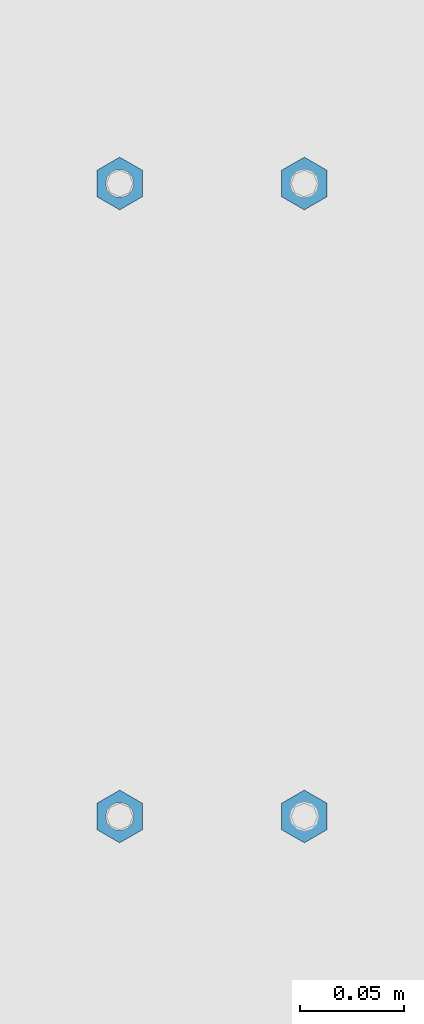
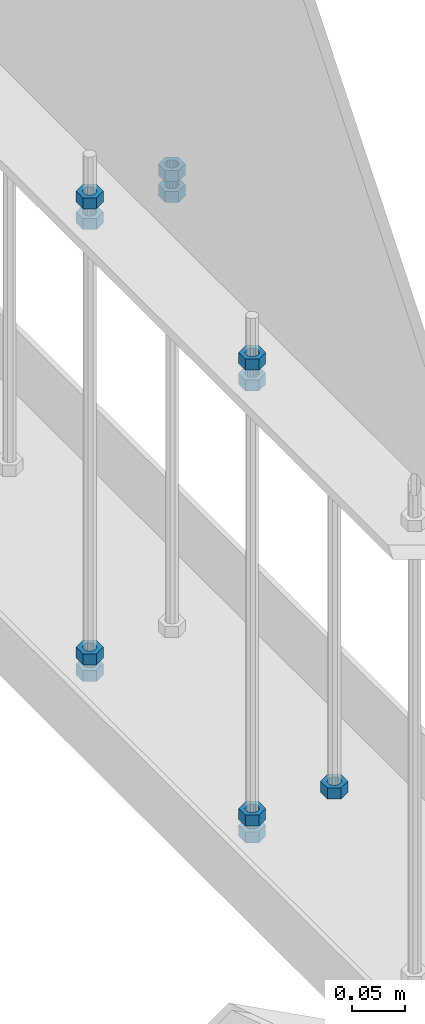
# One storey, part 294 of 975: 11 columns.
"""IFC2X3 building model written with IfcOpenShell, lengths in millimetres."""

from ifc_helpers import new_model, si_unit, frame, origin_with_axes, place, context, subcontext, project, spatial, faceted_brep, material, type_object, element, save


model = new_model("IFC2X3")

# Units and contexts
model_context = context("Model", 3, precision=1e-05, world=origin_with_axes())
body_context = subcontext(model_context, "Body", "Model", "MODEL_VIEW")
ifc_project = project(units=[si_unit("LENGTHUNIT", "METRE", prefix="MILLI"), si_unit("AREAUNIT", "SQUARE_METRE"), si_unit("VOLUMEUNIT", "CUBIC_METRE"), si_unit("MASSUNIT", "GRAM", prefix="KILO"), si_unit("TIMEUNIT", "SECOND"), si_unit("PLANEANGLEUNIT", "RADIAN"), si_unit("SOLIDANGLEUNIT", "STERADIAN"), si_unit("THERMODYNAMICTEMPERATUREUNIT", "DEGREE_CELSIUS"), si_unit("LUMINOUSINTENSITYUNIT", "LUMEN")], contexts=[model_context])

# Site, building, storey
site_placement = place(None, origin_with_axes())
site = spatial("IfcSite", under=ifc_project, at=site_placement, CompositionType="ELEMENT")
building_placement = place(site_placement, origin_with_axes())
building = spatial("IfcBuilding", under=site, at=building_placement, Name="Undefined", CompositionType="ELEMENT")
storey_placement = place(building_placement, origin_with_axes())
storey = spatial("IfcBuildingStorey", under=building, at=storey_placement, Name="Undefined", CompositionType="ELEMENT", Elevation=0.0)

# Columns
ifc_material = material(Name="STEEL/A307")
column_type = type_object("IfcColumnType", Name="1/2_HEAVY_HEX_NUT", PredefinedType="NOTDEFINED")
column_1_placement = place(storey_placement, frame((8274.05, 21726.525, 3400.425), z_axis=(-0.999999999999998, 6.90000001668524e-08, 0.0), x_axis=(0.0, 0.0, 1.0)))
element("IfcColumn", 1, at=column_1_placement, inside=storey, type_object=column_type, material=ifc_material, Name="NUT", ObjectType="1/2_HEAVY_HEX_NUT", context=body_context, shape_type="Brep", body=[
    faceted_brep([(0.0, -12.6999998092506, -1.09139364212751e-11), (0.0, -6.34999990461802, -11.0000000000218), (12.6999999999998, -6.34999990461802, -11.0000000000218), (12.6999999999998, -12.6999998092506, -1.09139364212751e-11), (0.0, 6.34999990463257, -11.0000000000109), (12.6999999999998, 6.34999990463257, -11.0000000000109), (0.0, 12.6999998092506, 1.09139364212751e-11), (12.6999999999998, 12.6999998092506, 1.09139364212751e-11), (0.0, 6.34999990461802, 11.0000000000218), (12.6999999999998, 6.34999990461802, 11.0000000000218), (0.0, -6.34999990463984, 11.0000000000109), (12.6999999999998, -6.34999990463984, 11.0000000000109), (0.0, -7.27595761418343e-12, 6.75000000000728), (0.0, 2.92871523903523, 6.08153985835088), (12.6999999999998, 2.92871523903523, 6.08153985835088), (12.6999999999998, -7.27595761418343e-12, 6.75000000000728), (0.0, 5.27736250664748, 4.20855616255722), (12.6999999999998, 5.27736250664748, 4.20855616255722), (0.0, 6.58076340721527, 1.50201630420997), (12.6999999999998, 6.58076340721527, 1.50201630420997), (0.0, 6.58076340722255, -1.5020163042027), (12.6999999999998, 6.58076340722255, -1.5020163042027), (0.0, 5.27736250665839, -4.20855616254994), (12.6999999999998, 5.27736250665839, -4.20855616254994), (0.0, 2.92871523904614, -6.08153985834724), (12.6999999999998, 2.92871523904614, -6.08153985834724), (0.0, 3.63797880709171e-12, -6.75000000001273), (12.6999999999998, 3.63797880709171e-12, -6.75000000001273), (0.0, -2.92871523903523, -6.08153985835452), (12.6999999999998, -2.92871523903523, -6.08153985835452), (0.0, -5.27736250665475, -4.20855616255722), (12.6999999999998, -5.27736250665475, -4.20855616255722), (0.0, -6.58076340721891, -1.50201630421179), (12.6999999999998, -6.58076340721891, -1.50201630421179), (0.0, -6.58076340722255, 1.50201630419906), (12.6999999999998, -6.58076340722255, 1.50201630419906), (0.0, -5.27736250665839, 4.20855616254994), (12.6999999999998, -5.27736250665839, 4.20855616254994), (0.0, -2.92871523904614, 6.08153985834724), (12.6999999999998, -2.92871523904614, 6.08153985834724)], [[[0, 1, 2, 3]], [[1, 4, 5, 2]], [[4, 6, 7, 5]], [[6, 8, 9, 7]], [[8, 10, 11, 9]], [[10, 0, 3, 11]], [[12, 13, 14, 15]], [[13, 16, 17, 14]], [[16, 18, 19, 17]], [[18, 20, 21, 19]], [[20, 22, 23, 21]], [[22, 24, 25, 23]], [[24, 26, 27, 25]], [[26, 28, 29, 27]], [[28, 30, 31, 29]], [[30, 32, 33, 31]], [[32, 34, 35, 33]], [[34, 36, 37, 35]], [[36, 38, 39, 37]], [[38, 12, 15, 39]], [[5, 7, 9, 11, 3, 2], [17, 19, 21, 23, 25, 27, 29, 31, 33, 35, 37, 39, 15, 14]], [[10, 8, 6, 4, 1, 0], [38, 36, 34, 32, 30, 28, 26, 24, 22, 20, 18, 16, 13, 12]]]),
])
column_2_placement = place(storey_placement, frame((8274.05, 21726.525, 3424.2375), z_axis=(-0.999999999999998, 6.90000001668524e-08, 0.0), x_axis=(0.0, 0.0, 1.0)))
element("IfcColumn", 2, at=column_2_placement, inside=storey, type_object=column_type, material=ifc_material, Name="NUT", ObjectType="1/2_HEAVY_HEX_NUT", context=body_context, shape_type="Brep", body=[
    faceted_brep([(0.0, -12.6999998092506, -1.09139364212751e-11), (0.0, -6.34999990461802, -11.0000000000218), (12.6999999999998, -6.34999990461802, -11.0000000000218), (12.6999999999998, -12.6999998092506, -1.09139364212751e-11), (0.0, 6.34999990463257, -11.0000000000109), (12.6999999999998, 6.34999990463257, -11.0000000000109), (0.0, 12.6999998092506, 1.09139364212751e-11), (12.6999999999998, 12.6999998092506, 1.09139364212751e-11), (0.0, 6.34999990461802, 11.0000000000218), (12.6999999999998, 6.34999990461802, 11.0000000000218), (0.0, -6.34999990463984, 11.0000000000109), (12.6999999999998, -6.34999990463984, 11.0000000000109), (0.0, -7.27595761418343e-12, 6.75000000000728), (0.0, 2.92871523903523, 6.08153985835088), (12.6999999999998, 2.92871523903523, 6.08153985835088), (12.6999999999998, -7.27595761418343e-12, 6.75000000000728), (0.0, 5.27736250664748, 4.20855616255722), (12.6999999999998, 5.27736250664748, 4.20855616255722), (0.0, 6.58076340721527, 1.50201630420997), (12.6999999999998, 6.58076340721527, 1.50201630420997), (0.0, 6.58076340722255, -1.5020163042027), (12.6999999999998, 6.58076340722255, -1.5020163042027), (0.0, 5.27736250665839, -4.20855616254994), (12.6999999999998, 5.27736250665839, -4.20855616254994), (0.0, 2.92871523904614, -6.08153985834724), (12.6999999999998, 2.92871523904614, -6.08153985834724), (0.0, 3.63797880709171e-12, -6.75000000001273), (12.6999999999998, 3.63797880709171e-12, -6.75000000001273), (0.0, -2.92871523903523, -6.08153985835452), (12.6999999999998, -2.92871523903523, -6.08153985835452), (0.0, -5.27736250665475, -4.20855616255722), (12.6999999999998, -5.27736250665475, -4.20855616255722), (0.0, -6.58076340721891, -1.50201630421179), (12.6999999999998, -6.58076340721891, -1.50201630421179), (0.0, -6.58076340722255, 1.50201630419906), (12.6999999999998, -6.58076340722255, 1.50201630419906), (0.0, -5.27736250665839, 4.20855616254994), (12.6999999999998, -5.27736250665839, 4.20855616254994), (0.0, -2.92871523904614, 6.08153985834724), (12.6999999999998, -2.92871523904614, 6.08153985834724)], [[[0, 1, 2, 3]], [[1, 4, 5, 2]], [[4, 6, 7, 5]], [[6, 8, 9, 7]], [[8, 10, 11, 9]], [[10, 0, 3, 11]], [[12, 13, 14, 15]], [[13, 16, 17, 14]], [[16, 18, 19, 17]], [[18, 20, 21, 19]], [[20, 22, 23, 21]], [[22, 24, 25, 23]], [[24, 26, 27, 25]], [[26, 28, 29, 27]], [[28, 30, 31, 29]], [[30, 32, 33, 31]], [[32, 34, 35, 33]], [[34, 36, 37, 35]], [[36, 38, 39, 37]], [[38, 12, 15, 39]], [[5, 7, 9, 11, 3, 2], [17, 19, 21, 23, 25, 27, 29, 31, 33, 35, 37, 39, 15, 14]], [[10, 8, 6, 4, 1, 0], [38, 36, 34, 32, 30, 28, 26, 24, 22, 20, 18, 16, 13, 12]]]),
])
column_3_placement = place(storey_placement, frame((8185.15, 21726.525, 2901.95), z_axis=(-0.999999999999998, 6.90000001668524e-08, 0.0), x_axis=(0.0, 0.0, 1.0)))
element("IfcColumn", 3, at=column_3_placement, inside=storey, type_object=column_type, material=ifc_material, Name="NUT", ObjectType="1/2_HEAVY_HEX_NUT", context=body_context, shape_type="Brep", body=[
    faceted_brep([(0.0, -12.6999998092506, -1.09139364212751e-11), (0.0, -6.34999990461802, -11.0000000000218), (12.6999999999998, -6.34999990461802, -11.0000000000218), (12.6999999999998, -12.6999998092506, -1.09139364212751e-11), (0.0, 6.34999990463257, -11.0000000000109), (12.6999999999998, 6.34999990463257, -11.0000000000109), (0.0, 12.6999998092506, 1.09139364212751e-11), (12.6999999999998, 12.6999998092506, 1.09139364212751e-11), (0.0, 6.34999990461802, 11.0000000000218), (12.6999999999998, 6.34999990461802, 11.0000000000218), (0.0, -6.34999990463984, 11.0000000000109), (12.6999999999998, -6.34999990463984, 11.0000000000109), (0.0, -7.27595761418343e-12, 6.75000000000728), (0.0, 2.92871523903523, 6.08153985835088), (12.6999999999998, 2.92871523903523, 6.08153985835088), (12.6999999999998, -7.27595761418343e-12, 6.75000000000728), (0.0, 5.27736250664748, 4.20855616255722), (12.6999999999998, 5.27736250664748, 4.20855616255722), (0.0, 6.58076340721527, 1.50201630420997), (12.6999999999998, 6.58076340721527, 1.50201630420997), (0.0, 6.58076340722255, -1.5020163042027), (12.6999999999998, 6.58076340722255, -1.5020163042027), (0.0, 5.27736250665839, -4.20855616254994), (12.6999999999998, 5.27736250665839, -4.20855616254994), (0.0, 2.92871523904614, -6.08153985834724), (12.6999999999998, 2.92871523904614, -6.08153985834724), (0.0, 3.63797880709171e-12, -6.75000000001273), (12.6999999999998, 3.63797880709171e-12, -6.75000000001273), (0.0, -2.92871523903523, -6.08153985835452), (12.6999999999998, -2.92871523903523, -6.08153985835452), (0.0, -5.27736250665475, -4.20855616255722), (12.6999999999998, -5.27736250665475, -4.20855616255722), (0.0, -6.58076340721891, -1.50201630421179), (12.6999999999998, -6.58076340721891, -1.50201630421179), (0.0, -6.58076340722255, 1.50201630419906), (12.6999999999998, -6.58076340722255, 1.50201630419906), (0.0, -5.27736250665839, 4.20855616254994), (12.6999999999998, -5.27736250665839, 4.20855616254994), (0.0, -2.92871523904614, 6.08153985834724), (12.6999999999998, -2.92871523904614, 6.08153985834724)], [[[0, 1, 2, 3]], [[1, 4, 5, 2]], [[4, 6, 7, 5]], [[6, 8, 9, 7]], [[8, 10, 11, 9]], [[10, 0, 3, 11]], [[12, 13, 14, 15]], [[13, 16, 17, 14]], [[16, 18, 19, 17]], [[18, 20, 21, 19]], [[20, 22, 23, 21]], [[22, 24, 25, 23]], [[24, 26, 27, 25]], [[26, 28, 29, 27]], [[28, 30, 31, 29]], [[30, 32, 33, 31]], [[32, 34, 35, 33]], [[34, 36, 37, 35]], [[36, 38, 39, 37]], [[38, 12, 15, 39]], [[5, 7, 9, 11, 3, 2], [17, 19, 21, 23, 25, 27, 29, 31, 33, 35, 37, 39, 15, 14]], [[10, 8, 6, 4, 1, 0], [38, 36, 34, 32, 30, 28, 26, 24, 22, 20, 18, 16, 13, 12]]]),
])
column_4_placement = place(storey_placement, frame((8185.15, 21726.525, 2882.9), z_axis=(-0.999999999999998, 6.90000001668524e-08, 0.0), x_axis=(0.0, 0.0, 1.0)))
element("IfcColumn", 4, at=column_4_placement, inside=storey, type_object=column_type, material=ifc_material, Name="NUT", ObjectType="1/2_HEAVY_HEX_NUT", context=body_context, shape_type="Brep", body=[
    faceted_brep([(0.0, -12.6999998092506, -1.09139364212751e-11), (0.0, -6.34999990461802, -11.0000000000218), (12.6999999999998, -6.34999990461802, -11.0000000000218), (12.6999999999998, -12.6999998092506, -1.09139364212751e-11), (0.0, 6.34999990463257, -11.0000000000109), (12.6999999999998, 6.34999990463257, -11.0000000000109), (0.0, 12.6999998092506, 1.09139364212751e-11), (12.6999999999998, 12.6999998092506, 1.09139364212751e-11), (0.0, 6.34999990461802, 11.0000000000218), (12.6999999999998, 6.34999990461802, 11.0000000000218), (0.0, -6.34999990463984, 11.0000000000109), (12.6999999999998, -6.34999990463984, 11.0000000000109), (0.0, -7.27595761418343e-12, 6.75000000000728), (0.0, 2.92871523903523, 6.08153985835088), (12.6999999999998, 2.92871523903523, 6.08153985835088), (12.6999999999998, -7.27595761418343e-12, 6.75000000000728), (0.0, 5.27736250664748, 4.20855616255722), (12.6999999999998, 5.27736250664748, 4.20855616255722), (0.0, 6.58076340721527, 1.50201630420997), (12.6999999999998, 6.58076340721527, 1.50201630420997), (0.0, 6.58076340722255, -1.5020163042027), (12.6999999999998, 6.58076340722255, -1.5020163042027), (0.0, 5.27736250665839, -4.20855616254994), (12.6999999999998, 5.27736250665839, -4.20855616254994), (0.0, 2.92871523904614, -6.08153985834724), (12.6999999999998, 2.92871523904614, -6.08153985834724), (0.0, 3.63797880709171e-12, -6.75000000001273), (12.6999999999998, 3.63797880709171e-12, -6.75000000001273), (0.0, -2.92871523903523, -6.08153985835452), (12.6999999999998, -2.92871523903523, -6.08153985835452), (0.0, -5.27736250665475, -4.20855616255722), (12.6999999999998, -5.27736250665475, -4.20855616255722), (0.0, -6.58076340721891, -1.50201630421179), (12.6999999999998, -6.58076340721891, -1.50201630421179), (0.0, -6.58076340722255, 1.50201630419906), (12.6999999999998, -6.58076340722255, 1.50201630419906), (0.0, -5.27736250665839, 4.20855616254994), (12.6999999999998, -5.27736250665839, 4.20855616254994), (0.0, -2.92871523904614, 6.08153985834724), (12.6999999999998, -2.92871523904614, 6.08153985834724)], [[[0, 1, 2, 3]], [[1, 4, 5, 2]], [[4, 6, 7, 5]], [[6, 8, 9, 7]], [[8, 10, 11, 9]], [[10, 0, 3, 11]], [[12, 13, 14, 15]], [[13, 16, 17, 14]], [[16, 18, 19, 17]], [[18, 20, 21, 19]], [[20, 22, 23, 21]], [[22, 24, 25, 23]], [[24, 26, 27, 25]], [[26, 28, 29, 27]], [[28, 30, 31, 29]], [[30, 32, 33, 31]], [[32, 34, 35, 33]], [[34, 36, 37, 35]], [[36, 38, 39, 37]], [[38, 12, 15, 39]], [[5, 7, 9, 11, 3, 2], [17, 19, 21, 23, 25, 27, 29, 31, 33, 35, 37, 39, 15, 14]], [[10, 8, 6, 4, 1, 0], [38, 36, 34, 32, 30, 28, 26, 24, 22, 20, 18, 16, 13, 12]]]),
])
column_5_placement = place(storey_placement, frame((8185.15, 21726.525, 3400.425), z_axis=(-0.999999999999998, 6.90000001668524e-08, 0.0), x_axis=(0.0, 0.0, 1.0)))
element("IfcColumn", 5, at=column_5_placement, inside=storey, type_object=column_type, material=ifc_material, Name="NUT", ObjectType="1/2_HEAVY_HEX_NUT", context=body_context, shape_type="Brep", body=[
    faceted_brep([(0.0, -12.6999998092506, -1.09139364212751e-11), (0.0, -6.34999990461802, -11.0000000000218), (12.6999999999998, -6.34999990461802, -11.0000000000218), (12.6999999999998, -12.6999998092506, -1.09139364212751e-11), (0.0, 6.34999990463257, -11.0000000000109), (12.6999999999998, 6.34999990463257, -11.0000000000109), (0.0, 12.6999998092506, 1.09139364212751e-11), (12.6999999999998, 12.6999998092506, 1.09139364212751e-11), (0.0, 6.34999990461802, 11.0000000000218), (12.6999999999998, 6.34999990461802, 11.0000000000218), (0.0, -6.34999990463984, 11.0000000000109), (12.6999999999998, -6.34999990463984, 11.0000000000109), (0.0, -7.27595761418343e-12, 6.75000000000728), (0.0, 2.92871523903523, 6.08153985835088), (12.6999999999998, 2.92871523903523, 6.08153985835088), (12.6999999999998, -7.27595761418343e-12, 6.75000000000728), (0.0, 5.27736250664748, 4.20855616255722), (12.6999999999998, 5.27736250664748, 4.20855616255722), (0.0, 6.58076340721527, 1.50201630420997), (12.6999999999998, 6.58076340721527, 1.50201630420997), (0.0, 6.58076340722255, -1.5020163042027), (12.6999999999998, 6.58076340722255, -1.5020163042027), (0.0, 5.27736250665839, -4.20855616254994), (12.6999999999998, 5.27736250665839, -4.20855616254994), (0.0, 2.92871523904614, -6.08153985834724), (12.6999999999998, 2.92871523904614, -6.08153985834724), (0.0, 3.63797880709171e-12, -6.75000000001273), (12.6999999999998, 3.63797880709171e-12, -6.75000000001273), (0.0, -2.92871523903523, -6.08153985835452), (12.6999999999998, -2.92871523903523, -6.08153985835452), (0.0, -5.27736250665475, -4.20855616255722), (12.6999999999998, -5.27736250665475, -4.20855616255722), (0.0, -6.58076340721891, -1.50201630421179), (12.6999999999998, -6.58076340721891, -1.50201630421179), (0.0, -6.58076340722255, 1.50201630419906), (12.6999999999998, -6.58076340722255, 1.50201630419906), (0.0, -5.27736250665839, 4.20855616254994), (12.6999999999998, -5.27736250665839, 4.20855616254994), (0.0, -2.92871523904614, 6.08153985834724), (12.6999999999998, -2.92871523904614, 6.08153985834724)], [[[0, 1, 2, 3]], [[1, 4, 5, 2]], [[4, 6, 7, 5]], [[6, 8, 9, 7]], [[8, 10, 11, 9]], [[10, 0, 3, 11]], [[12, 13, 14, 15]], [[13, 16, 17, 14]], [[16, 18, 19, 17]], [[18, 20, 21, 19]], [[20, 22, 23, 21]], [[22, 24, 25, 23]], [[24, 26, 27, 25]], [[26, 28, 29, 27]], [[28, 30, 31, 29]], [[30, 32, 33, 31]], [[32, 34, 35, 33]], [[34, 36, 37, 35]], [[36, 38, 39, 37]], [[38, 12, 15, 39]], [[5, 7, 9, 11, 3, 2], [17, 19, 21, 23, 25, 27, 29, 31, 33, 35, 37, 39, 15, 14]], [[10, 8, 6, 4, 1, 0], [38, 36, 34, 32, 30, 28, 26, 24, 22, 20, 18, 16, 13, 12]]]),
])
column_6_placement = place(storey_placement, frame((8185.15, 21726.525, 3424.2375), z_axis=(-0.999999999999998, 6.90000001668524e-08, 0.0), x_axis=(0.0, 0.0, 1.0)))
element("IfcColumn", 6, at=column_6_placement, inside=storey, type_object=column_type, material=ifc_material, Name="NUT", ObjectType="1/2_HEAVY_HEX_NUT", context=body_context, shape_type="Brep", body=[
    faceted_brep([(0.0, -12.6999998092506, -1.09139364212751e-11), (0.0, -6.34999990461802, -11.0000000000218), (12.6999999999998, -6.34999990461802, -11.0000000000218), (12.6999999999998, -12.6999998092506, -1.09139364212751e-11), (0.0, 6.34999990463257, -11.0000000000109), (12.6999999999998, 6.34999990463257, -11.0000000000109), (0.0, 12.6999998092506, 1.09139364212751e-11), (12.6999999999998, 12.6999998092506, 1.09139364212751e-11), (0.0, 6.34999990461802, 11.0000000000218), (12.6999999999998, 6.34999990461802, 11.0000000000218), (0.0, -6.34999990463984, 11.0000000000109), (12.6999999999998, -6.34999990463984, 11.0000000000109), (0.0, -7.27595761418343e-12, 6.75000000000728), (0.0, 2.92871523903523, 6.08153985835088), (12.6999999999998, 2.92871523903523, 6.08153985835088), (12.6999999999998, -7.27595761418343e-12, 6.75000000000728), (0.0, 5.27736250664748, 4.20855616255722), (12.6999999999998, 5.27736250664748, 4.20855616255722), (0.0, 6.58076340721527, 1.50201630420997), (12.6999999999998, 6.58076340721527, 1.50201630420997), (0.0, 6.58076340722255, -1.5020163042027), (12.6999999999998, 6.58076340722255, -1.5020163042027), (0.0, 5.27736250665839, -4.20855616254994), (12.6999999999998, 5.27736250665839, -4.20855616254994), (0.0, 2.92871523904614, -6.08153985834724), (12.6999999999998, 2.92871523904614, -6.08153985834724), (0.0, 3.63797880709171e-12, -6.75000000001273), (12.6999999999998, 3.63797880709171e-12, -6.75000000001273), (0.0, -2.92871523903523, -6.08153985835452), (12.6999999999998, -2.92871523903523, -6.08153985835452), (0.0, -5.27736250665475, -4.20855616255722), (12.6999999999998, -5.27736250665475, -4.20855616255722), (0.0, -6.58076340721891, -1.50201630421179), (12.6999999999998, -6.58076340721891, -1.50201630421179), (0.0, -6.58076340722255, 1.50201630419906), (12.6999999999998, -6.58076340722255, 1.50201630419906), (0.0, -5.27736250665839, 4.20855616254994), (12.6999999999998, -5.27736250665839, 4.20855616254994), (0.0, -2.92871523904614, 6.08153985834724), (12.6999999999998, -2.92871523904614, 6.08153985834724)], [[[0, 1, 2, 3]], [[1, 4, 5, 2]], [[4, 6, 7, 5]], [[6, 8, 9, 7]], [[8, 10, 11, 9]], [[10, 0, 3, 11]], [[12, 13, 14, 15]], [[13, 16, 17, 14]], [[16, 18, 19, 17]], [[18, 20, 21, 19]], [[20, 22, 23, 21]], [[22, 24, 25, 23]], [[24, 26, 27, 25]], [[26, 28, 29, 27]], [[28, 30, 31, 29]], [[30, 32, 33, 31]], [[32, 34, 35, 33]], [[34, 36, 37, 35]], [[36, 38, 39, 37]], [[38, 12, 15, 39]], [[5, 7, 9, 11, 3, 2], [17, 19, 21, 23, 25, 27, 29, 31, 33, 35, 37, 39, 15, 14]], [[10, 8, 6, 4, 1, 0], [38, 36, 34, 32, 30, 28, 26, 24, 22, 20, 18, 16, 13, 12]]]),
])
column_7_placement = place(storey_placement, frame((8185.15, 21421.725, 2901.95), z_axis=(-0.999999999999998, 6.90000001668524e-08, 0.0), x_axis=(0.0, 0.0, 1.0)))
element("IfcColumn", 7, at=column_7_placement, inside=storey, type_object=column_type, material=ifc_material, Name="NUT", ObjectType="1/2_HEAVY_HEX_NUT", context=body_context, shape_type="Brep", body=[
    faceted_brep([(0.0, -12.6999998092506, -1.09139364212751e-11), (0.0, -6.34999990461802, -11.0000000000218), (12.6999999999998, -6.34999990461802, -11.0000000000218), (12.6999999999998, -12.6999998092506, -1.09139364212751e-11), (0.0, 6.34999990463257, -11.0000000000109), (12.6999999999998, 6.34999990463257, -11.0000000000109), (0.0, 12.6999998092506, 1.09139364212751e-11), (12.6999999999998, 12.6999998092506, 1.09139364212751e-11), (0.0, 6.34999990461802, 11.0000000000218), (12.6999999999998, 6.34999990461802, 11.0000000000218), (0.0, -6.34999990463984, 11.0000000000109), (12.6999999999998, -6.34999990463984, 11.0000000000109), (0.0, -7.27595761418343e-12, 6.75000000000728), (0.0, 2.92871523903523, 6.08153985835088), (12.6999999999998, 2.92871523903523, 6.08153985835088), (12.6999999999998, -7.27595761418343e-12, 6.75000000000728), (0.0, 5.27736250664748, 4.20855616255722), (12.6999999999998, 5.27736250664748, 4.20855616255722), (0.0, 6.58076340721527, 1.50201630420997), (12.6999999999998, 6.58076340721527, 1.50201630420997), (0.0, 6.58076340722255, -1.5020163042027), (12.6999999999998, 6.58076340722255, -1.5020163042027), (0.0, 5.27736250665839, -4.20855616254994), (12.6999999999998, 5.27736250665839, -4.20855616254994), (0.0, 2.92871523904614, -6.08153985834724), (12.6999999999998, 2.92871523904614, -6.08153985834724), (0.0, 3.63797880709171e-12, -6.75000000001273), (12.6999999999998, 3.63797880709171e-12, -6.75000000001273), (0.0, -2.92871523903523, -6.08153985835452), (12.6999999999998, -2.92871523903523, -6.08153985835452), (0.0, -5.27736250665475, -4.20855616255722), (12.6999999999998, -5.27736250665475, -4.20855616255722), (0.0, -6.58076340721891, -1.50201630421179), (12.6999999999998, -6.58076340721891, -1.50201630421179), (0.0, -6.58076340722255, 1.50201630419906), (12.6999999999998, -6.58076340722255, 1.50201630419906), (0.0, -5.27736250665839, 4.20855616254994), (12.6999999999998, -5.27736250665839, 4.20855616254994), (0.0, -2.92871523904614, 6.08153985834724), (12.6999999999998, -2.92871523904614, 6.08153985834724)], [[[0, 1, 2, 3]], [[1, 4, 5, 2]], [[4, 6, 7, 5]], [[6, 8, 9, 7]], [[8, 10, 11, 9]], [[10, 0, 3, 11]], [[12, 13, 14, 15]], [[13, 16, 17, 14]], [[16, 18, 19, 17]], [[18, 20, 21, 19]], [[20, 22, 23, 21]], [[22, 24, 25, 23]], [[24, 26, 27, 25]], [[26, 28, 29, 27]], [[28, 30, 31, 29]], [[30, 32, 33, 31]], [[32, 34, 35, 33]], [[34, 36, 37, 35]], [[36, 38, 39, 37]], [[38, 12, 15, 39]], [[5, 7, 9, 11, 3, 2], [17, 19, 21, 23, 25, 27, 29, 31, 33, 35, 37, 39, 15, 14]], [[10, 8, 6, 4, 1, 0], [38, 36, 34, 32, 30, 28, 26, 24, 22, 20, 18, 16, 13, 12]]]),
])
column_8_placement = place(storey_placement, frame((8185.15, 21421.725, 2882.9), z_axis=(-0.999999999999998, 6.90000001668524e-08, 0.0), x_axis=(0.0, 0.0, 1.0)))
element("IfcColumn", 8, at=column_8_placement, inside=storey, type_object=column_type, material=ifc_material, Name="NUT", ObjectType="1/2_HEAVY_HEX_NUT", context=body_context, shape_type="Brep", body=[
    faceted_brep([(0.0, -12.6999998092506, -1.09139364212751e-11), (0.0, -6.34999990461802, -11.0000000000218), (12.6999999999998, -6.34999990461802, -11.0000000000218), (12.6999999999998, -12.6999998092506, -1.09139364212751e-11), (0.0, 6.34999990463257, -11.0000000000109), (12.6999999999998, 6.34999990463257, -11.0000000000109), (0.0, 12.6999998092506, 1.09139364212751e-11), (12.6999999999998, 12.6999998092506, 1.09139364212751e-11), (0.0, 6.34999990461802, 11.0000000000218), (12.6999999999998, 6.34999990461802, 11.0000000000218), (0.0, -6.34999990463984, 11.0000000000109), (12.6999999999998, -6.34999990463984, 11.0000000000109), (0.0, -7.27595761418343e-12, 6.75000000000728), (0.0, 2.92871523903523, 6.08153985835088), (12.6999999999998, 2.92871523903523, 6.08153985835088), (12.6999999999998, -7.27595761418343e-12, 6.75000000000728), (0.0, 5.27736250664748, 4.20855616255722), (12.6999999999998, 5.27736250664748, 4.20855616255722), (0.0, 6.58076340721527, 1.50201630420997), (12.6999999999998, 6.58076340721527, 1.50201630420997), (0.0, 6.58076340722255, -1.5020163042027), (12.6999999999998, 6.58076340722255, -1.5020163042027), (0.0, 5.27736250665839, -4.20855616254994), (12.6999999999998, 5.27736250665839, -4.20855616254994), (0.0, 2.92871523904614, -6.08153985834724), (12.6999999999998, 2.92871523904614, -6.08153985834724), (0.0, 3.63797880709171e-12, -6.75000000001273), (12.6999999999998, 3.63797880709171e-12, -6.75000000001273), (0.0, -2.92871523903523, -6.08153985835452), (12.6999999999998, -2.92871523903523, -6.08153985835452), (0.0, -5.27736250665475, -4.20855616255722), (12.6999999999998, -5.27736250665475, -4.20855616255722), (0.0, -6.58076340721891, -1.50201630421179), (12.6999999999998, -6.58076340721891, -1.50201630421179), (0.0, -6.58076340722255, 1.50201630419906), (12.6999999999998, -6.58076340722255, 1.50201630419906), (0.0, -5.27736250665839, 4.20855616254994), (12.6999999999998, -5.27736250665839, 4.20855616254994), (0.0, -2.92871523904614, 6.08153985834724), (12.6999999999998, -2.92871523904614, 6.08153985834724)], [[[0, 1, 2, 3]], [[1, 4, 5, 2]], [[4, 6, 7, 5]], [[6, 8, 9, 7]], [[8, 10, 11, 9]], [[10, 0, 3, 11]], [[12, 13, 14, 15]], [[13, 16, 17, 14]], [[16, 18, 19, 17]], [[18, 20, 21, 19]], [[20, 22, 23, 21]], [[22, 24, 25, 23]], [[24, 26, 27, 25]], [[26, 28, 29, 27]], [[28, 30, 31, 29]], [[30, 32, 33, 31]], [[32, 34, 35, 33]], [[34, 36, 37, 35]], [[36, 38, 39, 37]], [[38, 12, 15, 39]], [[5, 7, 9, 11, 3, 2], [17, 19, 21, 23, 25, 27, 29, 31, 33, 35, 37, 39, 15, 14]], [[10, 8, 6, 4, 1, 0], [38, 36, 34, 32, 30, 28, 26, 24, 22, 20, 18, 16, 13, 12]]]),
])
column_9_placement = place(storey_placement, frame((8185.15, 21421.725, 3400.425), z_axis=(-0.999999999999998, 6.90000001668524e-08, 0.0), x_axis=(0.0, 0.0, 1.0)))
element("IfcColumn", 9, at=column_9_placement, inside=storey, type_object=column_type, material=ifc_material, Name="NUT", ObjectType="1/2_HEAVY_HEX_NUT", context=body_context, shape_type="Brep", body=[
    faceted_brep([(0.0, -12.6999998092506, -1.09139364212751e-11), (0.0, -6.34999990461802, -11.0000000000218), (12.6999999999998, -6.34999990461802, -11.0000000000218), (12.6999999999998, -12.6999998092506, -1.09139364212751e-11), (0.0, 6.34999990463257, -11.0000000000109), (12.6999999999998, 6.34999990463257, -11.0000000000109), (0.0, 12.6999998092506, 1.09139364212751e-11), (12.6999999999998, 12.6999998092506, 1.09139364212751e-11), (0.0, 6.34999990461802, 11.0000000000218), (12.6999999999998, 6.34999990461802, 11.0000000000218), (0.0, -6.34999990463984, 11.0000000000109), (12.6999999999998, -6.34999990463984, 11.0000000000109), (0.0, -7.27595761418343e-12, 6.75000000000728), (0.0, 2.92871523903523, 6.08153985835088), (12.6999999999998, 2.92871523903523, 6.08153985835088), (12.6999999999998, -7.27595761418343e-12, 6.75000000000728), (0.0, 5.27736250664748, 4.20855616255722), (12.6999999999998, 5.27736250664748, 4.20855616255722), (0.0, 6.58076340721527, 1.50201630420997), (12.6999999999998, 6.58076340721527, 1.50201630420997), (0.0, 6.58076340722255, -1.5020163042027), (12.6999999999998, 6.58076340722255, -1.5020163042027), (0.0, 5.27736250665839, -4.20855616254994), (12.6999999999998, 5.27736250665839, -4.20855616254994), (0.0, 2.92871523904614, -6.08153985834724), (12.6999999999998, 2.92871523904614, -6.08153985834724), (0.0, 3.63797880709171e-12, -6.75000000001273), (12.6999999999998, 3.63797880709171e-12, -6.75000000001273), (0.0, -2.92871523903523, -6.08153985835452), (12.6999999999998, -2.92871523903523, -6.08153985835452), (0.0, -5.27736250665475, -4.20855616255722), (12.6999999999998, -5.27736250665475, -4.20855616255722), (0.0, -6.58076340721891, -1.50201630421179), (12.6999999999998, -6.58076340721891, -1.50201630421179), (0.0, -6.58076340722255, 1.50201630419906), (12.6999999999998, -6.58076340722255, 1.50201630419906), (0.0, -5.27736250665839, 4.20855616254994), (12.6999999999998, -5.27736250665839, 4.20855616254994), (0.0, -2.92871523904614, 6.08153985834724), (12.6999999999998, -2.92871523904614, 6.08153985834724)], [[[0, 1, 2, 3]], [[1, 4, 5, 2]], [[4, 6, 7, 5]], [[6, 8, 9, 7]], [[8, 10, 11, 9]], [[10, 0, 3, 11]], [[12, 13, 14, 15]], [[13, 16, 17, 14]], [[16, 18, 19, 17]], [[18, 20, 21, 19]], [[20, 22, 23, 21]], [[22, 24, 25, 23]], [[24, 26, 27, 25]], [[26, 28, 29, 27]], [[28, 30, 31, 29]], [[30, 32, 33, 31]], [[32, 34, 35, 33]], [[34, 36, 37, 35]], [[36, 38, 39, 37]], [[38, 12, 15, 39]], [[5, 7, 9, 11, 3, 2], [17, 19, 21, 23, 25, 27, 29, 31, 33, 35, 37, 39, 15, 14]], [[10, 8, 6, 4, 1, 0], [38, 36, 34, 32, 30, 28, 26, 24, 22, 20, 18, 16, 13, 12]]]),
])
column_10_placement = place(storey_placement, frame((8185.15, 21421.725, 3424.2375), z_axis=(-0.999999999999998, 6.90000001668524e-08, 0.0), x_axis=(0.0, 0.0, 1.0)))
element("IfcColumn", 10, at=column_10_placement, inside=storey, type_object=column_type, material=ifc_material, Name="NUT", ObjectType="1/2_HEAVY_HEX_NUT", context=body_context, shape_type="Brep", body=[
    faceted_brep([(0.0, -12.6999998092506, -1.09139364212751e-11), (0.0, -6.34999990461802, -11.0000000000218), (12.6999999999998, -6.34999990461802, -11.0000000000218), (12.6999999999998, -12.6999998092506, -1.09139364212751e-11), (0.0, 6.34999990463257, -11.0000000000109), (12.6999999999998, 6.34999990463257, -11.0000000000109), (0.0, 12.6999998092506, 1.09139364212751e-11), (12.6999999999998, 12.6999998092506, 1.09139364212751e-11), (0.0, 6.34999990461802, 11.0000000000218), (12.6999999999998, 6.34999990461802, 11.0000000000218), (0.0, -6.34999990463984, 11.0000000000109), (12.6999999999998, -6.34999990463984, 11.0000000000109), (0.0, -7.27595761418343e-12, 6.75000000000728), (0.0, 2.92871523903523, 6.08153985835088), (12.6999999999998, 2.92871523903523, 6.08153985835088), (12.6999999999998, -7.27595761418343e-12, 6.75000000000728), (0.0, 5.27736250664748, 4.20855616255722), (12.6999999999998, 5.27736250664748, 4.20855616255722), (0.0, 6.58076340721527, 1.50201630420997), (12.6999999999998, 6.58076340721527, 1.50201630420997), (0.0, 6.58076340722255, -1.5020163042027), (12.6999999999998, 6.58076340722255, -1.5020163042027), (0.0, 5.27736250665839, -4.20855616254994), (12.6999999999998, 5.27736250665839, -4.20855616254994), (0.0, 2.92871523904614, -6.08153985834724), (12.6999999999998, 2.92871523904614, -6.08153985834724), (0.0, 3.63797880709171e-12, -6.75000000001273), (12.6999999999998, 3.63797880709171e-12, -6.75000000001273), (0.0, -2.92871523903523, -6.08153985835452), (12.6999999999998, -2.92871523903523, -6.08153985835452), (0.0, -5.27736250665475, -4.20855616255722), (12.6999999999998, -5.27736250665475, -4.20855616255722), (0.0, -6.58076340721891, -1.50201630421179), (12.6999999999998, -6.58076340721891, -1.50201630421179), (0.0, -6.58076340722255, 1.50201630419906), (12.6999999999998, -6.58076340722255, 1.50201630419906), (0.0, -5.27736250665839, 4.20855616254994), (12.6999999999998, -5.27736250665839, 4.20855616254994), (0.0, -2.92871523904614, 6.08153985834724), (12.6999999999998, -2.92871523904614, 6.08153985834724)], [[[0, 1, 2, 3]], [[1, 4, 5, 2]], [[4, 6, 7, 5]], [[6, 8, 9, 7]], [[8, 10, 11, 9]], [[10, 0, 3, 11]], [[12, 13, 14, 15]], [[13, 16, 17, 14]], [[16, 18, 19, 17]], [[18, 20, 21, 19]], [[20, 22, 23, 21]], [[22, 24, 25, 23]], [[24, 26, 27, 25]], [[26, 28, 29, 27]], [[28, 30, 31, 29]], [[30, 32, 33, 31]], [[32, 34, 35, 33]], [[34, 36, 37, 35]], [[36, 38, 39, 37]], [[38, 12, 15, 39]], [[5, 7, 9, 11, 3, 2], [17, 19, 21, 23, 25, 27, 29, 31, 33, 35, 37, 39, 15, 14]], [[10, 8, 6, 4, 1, 0], [38, 36, 34, 32, 30, 28, 26, 24, 22, 20, 18, 16, 13, 12]]]),
])
column_11_placement = place(storey_placement, frame((8274.05, 21421.725, 2901.95), z_axis=(-0.999999999999998, 6.90000001668524e-08, 0.0), x_axis=(0.0, 0.0, 1.0)))
element("IfcColumn", 11, at=column_11_placement, inside=storey, type_object=column_type, material=ifc_material, Name="NUT", ObjectType="1/2_HEAVY_HEX_NUT", context=body_context, shape_type="Brep", body=[
    faceted_brep([(0.0, -12.6999998092506, -1.09139364212751e-11), (0.0, -6.34999990461802, -11.0000000000218), (12.6999999999998, -6.34999990461802, -11.0000000000218), (12.6999999999998, -12.6999998092506, -1.09139364212751e-11), (0.0, 6.34999990463257, -11.0000000000109), (12.6999999999998, 6.34999990463257, -11.0000000000109), (0.0, 12.6999998092506, 1.09139364212751e-11), (12.6999999999998, 12.6999998092506, 1.09139364212751e-11), (0.0, 6.34999990461802, 11.0000000000218), (12.6999999999998, 6.34999990461802, 11.0000000000218), (0.0, -6.34999990463984, 11.0000000000109), (12.6999999999998, -6.34999990463984, 11.0000000000109), (0.0, -7.27595761418343e-12, 6.75000000000728), (0.0, 2.92871523903523, 6.08153985835088), (12.6999999999998, 2.92871523903523, 6.08153985835088), (12.6999999999998, -7.27595761418343e-12, 6.75000000000728), (0.0, 5.27736250664748, 4.20855616255722), (12.6999999999998, 5.27736250664748, 4.20855616255722), (0.0, 6.58076340721527, 1.50201630420997), (12.6999999999998, 6.58076340721527, 1.50201630420997), (0.0, 6.58076340722255, -1.5020163042027), (12.6999999999998, 6.58076340722255, -1.5020163042027), (0.0, 5.27736250665839, -4.20855616254994), (12.6999999999998, 5.27736250665839, -4.20855616254994), (0.0, 2.92871523904614, -6.08153985834724), (12.6999999999998, 2.92871523904614, -6.08153985834724), (0.0, 3.63797880709171e-12, -6.75000000001273), (12.6999999999998, 3.63797880709171e-12, -6.75000000001273), (0.0, -2.92871523903523, -6.08153985835452), (12.6999999999998, -2.92871523903523, -6.08153985835452), (0.0, -5.27736250665475, -4.20855616255722), (12.6999999999998, -5.27736250665475, -4.20855616255722), (0.0, -6.58076340721891, -1.50201630421179), (12.6999999999998, -6.58076340721891, -1.50201630421179), (0.0, -6.58076340722255, 1.50201630419906), (12.6999999999998, -6.58076340722255, 1.50201630419906), (0.0, -5.27736250665839, 4.20855616254994), (12.6999999999998, -5.27736250665839, 4.20855616254994), (0.0, -2.92871523904614, 6.08153985834724), (12.6999999999998, -2.92871523904614, 6.08153985834724)], [[[0, 1, 2, 3]], [[1, 4, 5, 2]], [[4, 6, 7, 5]], [[6, 8, 9, 7]], [[8, 10, 11, 9]], [[10, 0, 3, 11]], [[12, 13, 14, 15]], [[13, 16, 17, 14]], [[16, 18, 19, 17]], [[18, 20, 21, 19]], [[20, 22, 23, 21]], [[22, 24, 25, 23]], [[24, 26, 27, 25]], [[26, 28, 29, 27]], [[28, 30, 31, 29]], [[30, 32, 33, 31]], [[32, 34, 35, 33]], [[34, 36, 37, 35]], [[36, 38, 39, 37]], [[38, 12, 15, 39]], [[5, 7, 9, 11, 3, 2], [17, 19, 21, 23, 25, 27, 29, 31, 33, 35, 37, 39, 15, 14]], [[10, 8, 6, 4, 1, 0], [38, 36, 34, 32, 30, 28, 26, 24, 22, 20, 18, 16, 13, 12]]]),
])

save(model, "model.ifc")
